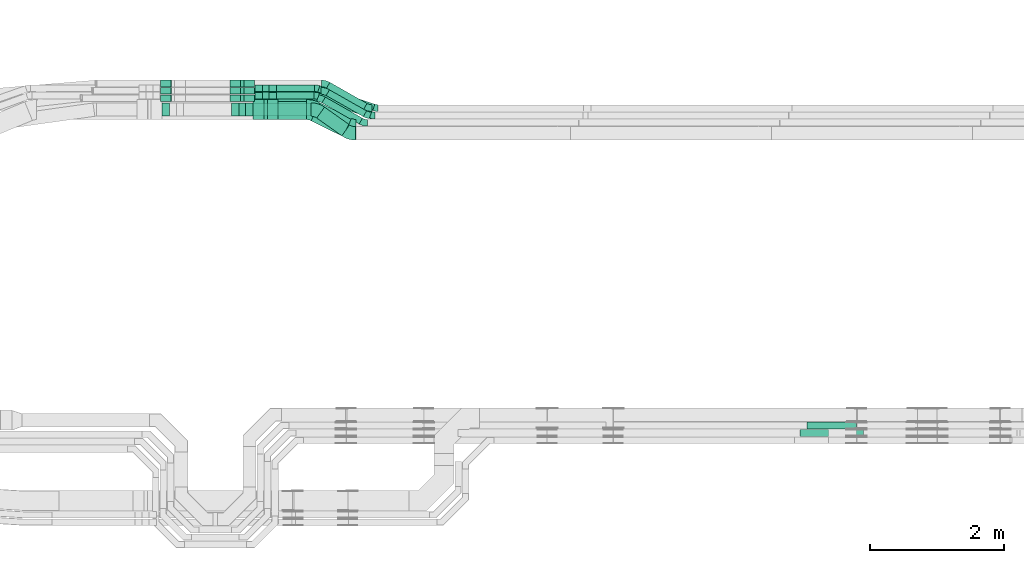
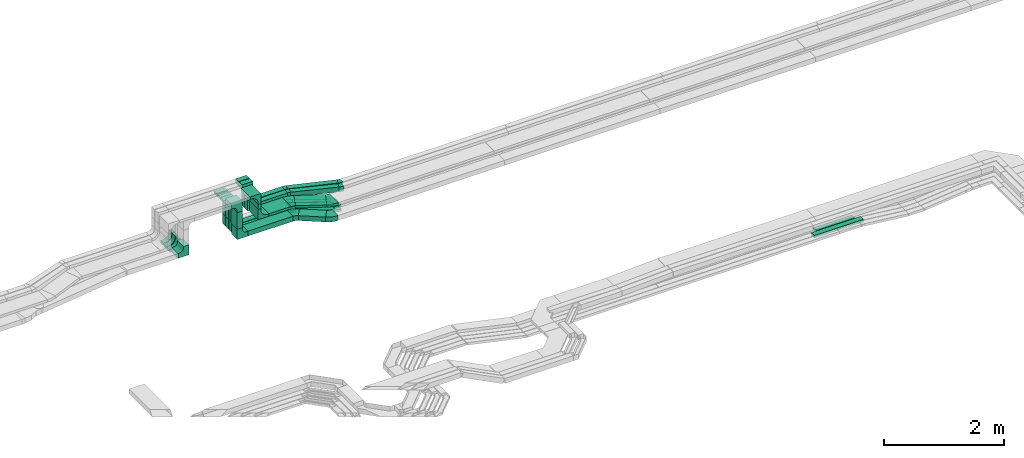
# One storey, part 17 of 32: 32 flow fittings, 22 flow segments.
"""IFC2X3 building model written with IfcOpenShell, lengths in millimetres."""

from ifc_helpers import new_model, entity, si_unit, converted_unit, derived_unit, direction, frame, frame_2d, origin, origin_2d_with_axis, place, context, subcontext, project, spatial, polyline, circle_curve, parameter, trimmed, segment, composite_curve, rectangle, outline, extrude, source, transform, mapped, material, type_object, type_shapes, element, save


model = new_model("IFC2X3")

# Units and contexts
model_context = context("Model", 3, precision=0.01, world=origin(), true_north=direction((6.12303176911189e-17, 1.0)))
body_context = subcontext(model_context, "Body", "Model", "MODEL_VIEW")
ifc_project = project(units=[si_unit("LENGTHUNIT", "METRE", prefix="MILLI"), si_unit("AREAUNIT", "SQUARE_METRE"), si_unit("VOLUMEUNIT", "CUBIC_METRE"), converted_unit("PLANEANGLEUNIT", "DEGREE", entity("IfcRatioMeasure", 0.0174532925199433), si_unit("PLANEANGLEUNIT", "RADIAN"), dimensions=[0, 0, 0, 0, 0, 0, 0]), si_unit("MASSUNIT", "GRAM", prefix="KILO"), derived_unit("MASSDENSITYUNIT", [(si_unit("MASSUNIT", "GRAM", prefix="KILO"), 1), (si_unit("LENGTHUNIT", "METRE"), -3)]), derived_unit("MOMENTOFINERTIAUNIT", [(si_unit("LENGTHUNIT", "METRE"), 4)]), si_unit("TIMEUNIT", "SECOND"), si_unit("FREQUENCYUNIT", "HERTZ"), si_unit("THERMODYNAMICTEMPERATUREUNIT", "DEGREE_CELSIUS"), derived_unit("THERMALTRANSMITTANCEUNIT", [(si_unit("MASSUNIT", "GRAM", prefix="KILO"), 1), (si_unit("THERMODYNAMICTEMPERATUREUNIT", "KELVIN"), -1), (si_unit("TIMEUNIT", "SECOND"), -3)]), derived_unit("VOLUMETRICFLOWRATEUNIT", [(si_unit("LENGTHUNIT", "METRE"), 3), (si_unit("TIMEUNIT", "SECOND"), -1)]), derived_unit("MASSFLOWRATEUNIT", [(si_unit("MASSUNIT", "GRAM", prefix="KILO"), 1), (si_unit("TIMEUNIT", "SECOND"), -1)]), derived_unit("ROTATIONALFREQUENCYUNIT", [(si_unit("TIMEUNIT", "SECOND"), -1)]), si_unit("ELECTRICCURRENTUNIT", "AMPERE"), si_unit("ELECTRICVOLTAGEUNIT", "VOLT"), si_unit("POWERUNIT", "WATT"), si_unit("FORCEUNIT", "NEWTON", prefix="KILO"), si_unit("ILLUMINANCEUNIT", "LUX"), si_unit("LUMINOUSFLUXUNIT", "LUMEN"), si_unit("LUMINOUSINTENSITYUNIT", "CANDELA"), derived_unit("USERDEFINED", [(si_unit("MASSUNIT", "GRAM", prefix="KILO"), -1), (si_unit("LENGTHUNIT", "METRE"), -2), (si_unit("TIMEUNIT", "SECOND"), 3), (si_unit("LUMINOUSFLUXUNIT", "LUMEN"), 1)]), derived_unit("LINEARVELOCITYUNIT", [(si_unit("LENGTHUNIT", "METRE"), 1), (si_unit("TIMEUNIT", "SECOND"), -1)]), si_unit("PRESSUREUNIT", "PASCAL"), derived_unit("USERDEFINED", [(si_unit("LENGTHUNIT", "METRE"), -2), (si_unit("MASSUNIT", "GRAM", prefix="KILO"), 1), (si_unit("TIMEUNIT", "SECOND"), -2)]), derived_unit("LINEARFORCEUNIT", [(si_unit("MASSUNIT", "GRAM", prefix="KILO"), 1), (si_unit("LENGTHUNIT", "METRE"), 1), (si_unit("TIMEUNIT", "SECOND"), -2), (si_unit("LENGTHUNIT", "METRE"), -1)]), derived_unit("PLANARFORCEUNIT", [(si_unit("MASSUNIT", "GRAM", prefix="KILO"), 1), (si_unit("LENGTHUNIT", "METRE"), 1), (si_unit("TIMEUNIT", "SECOND"), -2), (si_unit("LENGTHUNIT", "METRE"), -2)])], contexts=[model_context])

# Site, building, storey
site_placement = place(None, origin())
site = spatial("IfcSite", under=ifc_project, at=site_placement, CompositionType="ELEMENT")
building_placement = place(site_placement, origin())
building = spatial("IfcBuilding", under=site, at=building_placement, CompositionType="ELEMENT")
storey_placement = place(building_placement, frame((0.0, 0.0, 8100.0)))
storey = spatial("IfcBuildingStorey", under=building, at=storey_placement, CompositionType="ELEMENT", Elevation=8100.0)

# Flow segments
cable_carrier_segment_type = type_object("IfcCableCarrierSegmentType", PredefinedType="CABLETRAYSEGMENT")
flow_segment_1_placement = place(storey_placement, frame((30931.41, 14532.28, 2758.88)))
element("IfcFlowSegment", 1, at=flow_segment_1_placement, inside=storey, type_object=cable_carrier_segment_type, context=body_context, shape_type="SweptSolid", body=[
    extrude(rectangle(XDim=199.999999999998, YDim=100.000000000003, at=origin_2d_with_axis()), frame((50.0, 100.0, 0.0), z_axis=(0.0, 0.0, 1.0), x_axis=(0.0, -1.0, 0.0)), (0.0, 0.0, 1.0), 341.12169575336),
])
flow_segment_2_placement = place(storey_placement, frame((31166.41, 14750.06, 2548.88)))
element("IfcFlowSegment", 2, at=flow_segment_2_placement, inside=storey, type_object=cable_carrier_segment_type, context=body_context, shape_type="SweptSolid", body=[
    extrude(rectangle(XDim=930.329654405807, YDim=99.9999999999989, at=origin_2d_with_axis()), frame((465.16, 50.0, 0.0)), (0.0, 0.0, 1.0), 50.0000000000016),
])
flow_segment_3_placement = place(storey_placement, frame((30956.41, 14750.06, 2758.88)))
element("IfcFlowSegment", 3, at=flow_segment_3_placement, inside=storey, type_object=cable_carrier_segment_type, context=body_context, shape_type="SweptSolid", body=[
    extrude(rectangle(XDim=99.9999999999989, YDim=49.9999999999973, at=origin_2d_with_axis()), frame((25.0, 50.0, 0.0), z_axis=(0.0, 0.0, 1.0), x_axis=(0.0, -1.0, 0.0)), (0.0, 0.0, 1.0), 291.118753620383),
])
flow_segment_4_placement = place(storey_placement, frame((30956.41, 14860.06, 2758.35)))
element("IfcFlowSegment", 4, at=flow_segment_4_placement, inside=storey, type_object=cable_carrier_segment_type, context=body_context, shape_type="SweptSolid", body=[
    extrude(rectangle(XDim=99.9999999999989, YDim=49.9999999999973, at=origin_2d_with_axis()), frame((25.0, 50.0, 0.0), z_axis=(0.0, 0.0, 1.0), x_axis=(0.0, -1.0, 0.0)), (0.0, 0.0, 1.0), 291.650295473346),
])
flow_segment_5_placement = place(storey_placement, frame((39414.26, 9865.0, 2544.93)))
element("IfcFlowSegment", 5, at=flow_segment_5_placement, inside=storey, type_object=cable_carrier_segment_type, context=body_context, shape_type="SweptSolid", body=[
    extrude(rectangle(XDim=734.864056960746, YDim=99.9999999999989, at=origin_2d_with_axis()), frame((367.43, 50.0, 0.0)), (0.0, 0.0, 1.0), 50.0000000000016),
])
flow_segment_6_placement = place(storey_placement, frame((39304.26, 9755.0, 2546.32)))
element("IfcFlowSegment", 6, at=flow_segment_6_placement, inside=storey, type_object=cable_carrier_segment_type, context=body_context, shape_type="SweptSolid", body=[
    extrude(rectangle(XDim=948.992857325044, YDim=99.9999999999989, at=origin_2d_with_axis()), frame((474.5, 50.0, 0.0)), (0.0, 0.0, 1.0), 50.0000000000016),
])
flow_segment_7_placement = place(storey_placement, frame((30956.41, 14970.06, 2758.87)))
element("IfcFlowSegment", 7, at=flow_segment_7_placement, inside=storey, type_object=cable_carrier_segment_type, context=body_context, shape_type="SweptSolid", body=[
    extrude(rectangle(XDim=99.9999999999989, YDim=49.9999999999973, at=origin_2d_with_axis()), frame((25.0, 50.0, 0.0), z_axis=(0.0, 0.0, 1.0), x_axis=(0.0, -1.0, 0.0)), (0.0, 0.0, 1.0), 291.131430687611),
])
for number, where in (
    (8, (31281.41, 14900.06, 3065.0)),
    (9, (31281.41, 14790.06, 3065.0)),
):
    element("IfcFlowSegment", number, at=place(storey_placement, frame(where)), inside=storey, type_object=cable_carrier_segment_type, context=body_context, shape_type="SweptSolid", body=[
        extrude(rectangle(XDim=99.9999999999989, YDim=100.000000000003, at=origin_2d_with_axis()), frame((50.0, 50.0, 0.0), z_axis=(0.0, 0.0, 1.0), x_axis=(0.0, -1.0, 0.0)), (0.0, 0.0, 1.0), 149.998679724358),
    ])
flow_segment_8_placement = place(storey_placement, frame((31306.41, 14480.06, 3064.5)))
element("IfcFlowSegment", 10, at=flow_segment_8_placement, inside=storey, type_object=cable_carrier_segment_type, context=body_context, shape_type="SweptSolid", body=[
    extrude(rectangle(XDim=300.000000000001, YDim=49.9999999999973, at=origin_2d_with_axis()), frame((25.0, 150.0, 0.0), z_axis=(0.0, 0.0, 1.0), x_axis=(0.0, -1.0, 0.0)), (0.0, 0.0, 1.0), 100.501340766892),
])
flow_segment_9_placement = place(storey_placement, frame((31516.41, 14480.06, 2854.5)))
element("IfcFlowSegment", 11, at=flow_segment_9_placement, inside=storey, type_object=cable_carrier_segment_type, context=body_context, shape_type="SweptSolid", body=[
    extrude(rectangle(XDim=424.417391840432, YDim=300.000000000001, at=origin_2d_with_axis()), frame((212.21, 150.0, 0.0)), (0.0, 0.0, 1.0), 50.0000000000016),
])
flow_segment_10_placement = place(storey_placement, frame((31166.41, 14860.06, 2548.35)))
element("IfcFlowSegment", 12, at=flow_segment_10_placement, inside=storey, type_object=cable_carrier_segment_type, context=body_context, shape_type="SweptSolid", body=[
    extrude(rectangle(XDim=992.779967028208, YDim=99.9999999999989, at=origin_2d_with_axis()), frame((496.39, 50.0, 0.0), z_axis=(0.0, 0.0, 1.0), x_axis=(-1.0, 0.0, 0.0)), (0.0, 0.0, 1.0), 50.0000000000016),
])
flow_segment_11_placement = place(storey_placement, frame((31141.41, 14532.28, 2548.88)))
element("IfcFlowSegment", 13, at=flow_segment_11_placement, inside=storey, type_object=cable_carrier_segment_type, context=body_context, shape_type="SweptSolid", body=[
    extrude(rectangle(XDim=864.32109174626, YDim=199.999999999998, at=origin_2d_with_axis()), frame((432.16, 100.0, 0.0)), (0.0, 0.0, 1.0), 99.9999999999989),
])
flow_segment_12_placement = place(storey_placement, frame((32009.41, 14229.64, 2854.5)))
element("IfcFlowSegment", 14, at=flow_segment_12_placement, inside=storey, type_object=cable_carrier_segment_type, context=body_context, shape_type="SweptSolid", body=[
    extrude(rectangle(XDim=527.080933740967, YDim=299.999999999999, at=origin_2d_with_axis()), frame((302.75, 251.53, 0.0), z_axis=(0.0, 0.0, 1.0), x_axis=(-0.895736929927625, 0.444584471572987, 0.0)), (0.0, 0.0, 1.0), 50.0000000000016),
])
flow_segment_13_placement = place(storey_placement, frame((32094.18, 14239.35, 2548.88)))
element("IfcFlowSegment", 15, at=flow_segment_13_placement, inside=storey, type_object=cable_carrier_segment_type, context=body_context, shape_type="SweptSolid", body=[
    extrude(rectangle(XDim=458.510292454723, YDim=200.000000000002, at=origin_2d_with_axis()), frame((244.91, 214.04, 0.0), z_axis=(0.0, 0.0, 1.0), x_axis=(-0.816364917109081, 0.577536424923557, 0.0)), (0.0, 0.0, 1.0), 99.9999999999989),
])
flow_segment_14_placement = place(storey_placement, frame((32235.12, 14525.37, 2548.35)))
element("IfcFlowSegment", 16, at=flow_segment_14_placement, inside=storey, type_object=cable_carrier_segment_type, context=body_context, shape_type="SweptSolid", body=[
    extrude(rectangle(XDim=637.297455532549, YDim=100.000000000004, at=origin_2d_with_axis()), frame((301.79, 200.8, 0.0), z_axis=(0.0, 0.0, 1.0), x_axis=(-0.869625227484752, 0.493712430187952, 0.0)), (0.0, 0.0, 1.0), 50.0000000000016),
])
flow_segment_15_placement = place(storey_placement, frame((32172.67, 14415.37, 2548.88)))
element("IfcFlowSegment", 17, at=flow_segment_15_placement, inside=storey, type_object=cable_carrier_segment_type, context=body_context, shape_type="SweptSolid", body=[
    extrude(rectangle(XDim=637.297455532608, YDim=99.9999999999995, at=origin_2d_with_axis()), frame((301.79, 200.8, 0.0), z_axis=(0.0, 0.0, 1.0), x_axis=(-0.869625227484766, 0.493712430187927, 0.0)), (0.0, 0.0, 1.0), 50.0000000000016),
])
flow_segment_16_placement = place(storey_placement, frame((32240.6, 14635.37, 2548.87)))
element("IfcFlowSegment", 18, at=flow_segment_16_placement, inside=storey, type_object=cable_carrier_segment_type, context=body_context, shape_type="SweptSolid", body=[
    extrude(rectangle(XDim=637.297455532466, YDim=100.0, at=origin_2d_with_axis()), frame((301.79, 200.8, 0.0), z_axis=(0.0, 0.0, 1.0), x_axis=(-0.869625227484736, 0.49371243018798, 0.0)), (0.0, 0.0, 1.0), 50.0000000000016),
])
flow_segment_17_placement = place(storey_placement, frame((32109.51, 14615.66, 2855.0)))
element("IfcFlowSegment", 19, at=flow_segment_17_placement, inside=storey, type_object=cable_carrier_segment_type, context=body_context, shape_type="SweptSolid", body=[
    extrude(rectangle(XDim=865.944698440222, YDim=100.000000000001, at=origin_2d_with_axis()), frame((426.3, 185.51, 0.0), z_axis=(0.0, 0.0, 1.0), x_axis=(0.947752520609184, -0.319006519806318, 0.0)), (0.0, 0.0, 1.0), 99.9999999999989),
])
flow_segment_18_placement = place(storey_placement, frame((31491.41, 14900.06, 2855.0)))
element("IfcFlowSegment", 20, at=flow_segment_18_placement, inside=storey, type_object=cable_carrier_segment_type, context=body_context, shape_type="SweptSolid", body=[
    extrude(rectangle(XDim=568.300597632481, YDim=99.9999999999989, at=origin_2d_with_axis()), frame((284.15, 50.0, 0.0)), (0.0, 0.0, 1.0), 99.9999999999989),
])
flow_segment_19_placement = place(storey_placement, frame((32102.16, 14506.81, 2855.0)))
element("IfcFlowSegment", 21, at=flow_segment_19_placement, inside=storey, type_object=cable_carrier_segment_type, context=body_context, shape_type="SweptSolid", body=[
    extrude(rectangle(XDim=826.032338291808, YDim=99.9999999999999, at=origin_2d_with_axis()), frame((406.17, 184.36, 0.0), z_axis=(0.0, 0.0, 1.0), x_axis=(0.943212511924906, -0.332189941672396, 0.0)), (0.0, 0.0, 1.0), 99.9999999999989),
])
flow_segment_20_placement = place(storey_placement, frame((31491.41, 14790.06, 2855.0)))
element("IfcFlowSegment", 22, at=flow_segment_20_placement, inside=storey, type_object=cable_carrier_segment_type, context=body_context, shape_type="SweptSolid", body=[
    extrude(rectangle(XDim=558.972805625544, YDim=99.9999999999989, at=origin_2d_with_axis()), frame((279.49, 50.0, 0.0)), (0.0, 0.0, 1.0), 99.9999999999989),
])

# Flow fittings
ifc_material = material()
cable_carrier_fitting_type_1 = type_object("IfcCableCarrierFittingType", Name="470_DKC_S5_CDV 90 external vertical angle:-", PredefinedType="NOTDEFINED", material=ifc_material)
shared_shape_1 = source(origin(), body_context, "Body", "SweptSolid", [
    extrude(outline(composite_curve([segment(polyline([(65.71, 14.29), (95.71, 14.29)]), True, "CONTINUOUS"), segment(polyline([(95.71, 14.29), (95.71, 114.29)]), True, "CONTINUOUS"), segment(polyline([(95.71, 114.29), (-114.29, 114.29)]), True, "CONTINUOUS"), segment(polyline([(-114.29, 114.29), (-114.29, -95.71)]), True, "CONTINUOUS"), segment(polyline([(-114.29, -95.71), (-14.29, -95.71)]), True, "CONTINUOUS"), segment(polyline([(-14.29, -95.71), (-14.29, -65.71)]), True, "CONTINUOUS"), segment(trimmed(circle_curve(frame_2d((65.71, -65.71), x_axis=(-1.0, 0.0)), 80.0), [parameter(270.0)], [parameter(2.54444374517082e-13)], True, "PARAMETER"), False, "CONTINUOUS")], self_intersect=False)), frame((-64.29, 64.29, -99.0), z_axis=(0.0, 0.0, 1.0), x_axis=(-1.0, 0.0, 0.0)), (0.0, 0.0, 1.0), 199.0),
])
type_shapes(cable_carrier_fitting_type_1, [shared_shape_1])
for number, where, z_axis, x_axis, name in (
    (23, (30981.41, 14632.28, 3260.0), (0.0, -1.0, 0.0), (0.0, 0.0, 1.0), "470_DKC_S5_90 external vertical angle"),
    (24, (30981.41, 14632.28, 2598.88), (0.0, -1.0, 0.0), (0.0, 0.0, -1.0), "470_DKC_S5_90 external vertical angle"),
    (25, (29948.2, 14632.28, 2615.0), (0.0, 1.0, 0.0), (0.0, 0.0, -1.0), "470_DKC_S5_90 external vertical angle"),
):
    element("IfcFlowFitting", number, at=place(storey_placement, frame(where, z_axis=z_axis, x_axis=x_axis)), inside=storey, type_object=cable_carrier_fitting_type_1, material=ifc_material, Name=name, ObjectType="470_DKC_S5_CDV 90 external vertical angle:-", context=body_context, shape_type="MappedRepresentation", body=[
        mapped(shared_shape_1, transform((0.0, 0.0, 0.0), scale=1.0)),
    ])
cable_carrier_fitting_type_2 = type_object("IfcCableCarrierFittingType", Name="470_DKC_S5_CDV 90 external vertical angle:-", PredefinedType="NOTDEFINED", material=ifc_material)
shared_shape_2 = source(origin(), body_context, "Body", "SweptSolid", [
    extrude(outline(composite_curve([segment(polyline([(80.0, 50.0), (110.0, 50.0)]), True, "CONTINUOUS"), segment(polyline([(110.0, 50.0), (110.0, 100.0)]), True, "CONTINUOUS"), segment(polyline([(110.0, 100.0), (-100.0, 100.0)]), True, "CONTINUOUS"), segment(polyline([(-100.0, 100.0), (-100.0, -110.0)]), True, "CONTINUOUS"), segment(polyline([(-100.0, -110.0), (-50.0, -110.0)]), True, "CONTINUOUS"), segment(polyline([(-50.0, -110.0), (-50.0, -80.0)]), True, "CONTINUOUS"), segment(trimmed(circle_curve(frame_2d((80.0, -80.0), x_axis=(-1.0, 0.0)), 130.0), [parameter(270.0)], [parameter(2.54444374517082e-13)], True, "PARAMETER"), False, "CONTINUOUS")], self_intersect=False)), frame((-75.0, 75.0, -49.0), z_axis=(0.0, 0.0, 1.0), x_axis=(-1.0, 0.0, 0.0)), (0.0, 0.0, 1.0), 99.0000000000002),
])
type_shapes(cable_carrier_fitting_type_2, [shared_shape_2])
for number, where, z_axis, x_axis, name in (
    (26, (30981.41, 14800.06, 3235.0), (0.0, -1.0, 0.0), (0.0, 0.0, 1.0), "470_DKC_S5_90 external vertical angle"),
    (27, (30981.41, 14910.06, 3235.0), (0.0, -1.0, 0.0), (0.0, 0.0, 1.0), "470_DKC_S5_90 external vertical angle"),
    (28, (30981.41, 15020.06, 3235.0), (0.0, -1.0, 0.0), (0.0, 0.0, 1.0), "470_DKC_S5_90 external vertical angle"),
    (29, (30981.41, 14910.06, 2573.35), (0.0, -1.0, 0.0), (0.0, 0.0, -1.0), "470_DKC_S5_90 external vertical angle"),
    (30, (30981.41, 14800.06, 2573.88), (0.0, -1.0, 0.0), (0.0, 0.0, -1.0), "470_DKC_S5_90 external vertical angle"),
    (31, (30981.41, 15020.06, 2573.87), (0.0, -1.0, 0.0), (0.0, 0.0, -1.0), "470_DKC_S5_90 external vertical angle"),
    (32, (29948.2, 14800.06, 2590.34), (0.0, 1.0, 0.0), (0.0, 0.0, -1.0), "470_DKC_S5_90 external vertical angle"),
    (33, (29948.2, 15020.06, 2595.0), (0.0, 1.0, 0.0), (0.0, 0.0, -1.0), "470_DKC_S5_90 external vertical angle"),
    (34, (29948.2, 14910.06, 2595.0), (0.0, 1.0, 0.0), (0.0, 0.0, -1.0), "470_DKC_S5_90 external vertical angle"),
):
    element("IfcFlowFitting", number, at=place(storey_placement, frame(where, z_axis=z_axis, x_axis=x_axis)), inside=storey, type_object=cable_carrier_fitting_type_2, material=ifc_material, Name=name, ObjectType="470_DKC_S5_CDV 90 external vertical angle:-", context=body_context, shape_type="MappedRepresentation", body=[
        mapped(shared_shape_2, transform((0.0, 0.0, 0.0), scale=1.0)),
    ])
cable_carrier_fitting_type_3 = type_object("IfcCableCarrierFittingType", Name="470_DKC_S5_CDV 90 external vertical angle:-", PredefinedType="NOTDEFINED", material=ifc_material)
shared_shape_3 = source(origin(), body_context, "Body", "SweptSolid", [
    extrude(outline(composite_curve([segment(polyline([(65.71, 14.29), (95.71, 14.29)]), True, "CONTINUOUS"), segment(polyline([(95.71, 14.29), (95.71, 114.29)]), True, "CONTINUOUS"), segment(polyline([(95.71, 114.29), (-114.29, 114.29)]), True, "CONTINUOUS"), segment(polyline([(-114.29, 114.29), (-114.29, -95.71)]), True, "CONTINUOUS"), segment(polyline([(-114.29, -95.71), (-14.29, -95.71)]), True, "CONTINUOUS"), segment(polyline([(-14.29, -95.71), (-14.29, -65.71)]), True, "CONTINUOUS"), segment(trimmed(circle_curve(frame_2d((65.71, -65.71), x_axis=(-1.0, 0.0)), 80.0), [parameter(270.0)], [parameter(2.54444374517082e-13)], True, "PARAMETER"), False, "CONTINUOUS")], self_intersect=False)), frame((-64.29, 64.29, -49.0), z_axis=(0.0, 0.0, 1.0), x_axis=(-1.0, 0.0, 0.0)), (0.0, 0.0, 1.0), 99.0000000000002),
])
type_shapes(cable_carrier_fitting_type_3, [shared_shape_3])
for number, where, z_axis, x_axis, name in (
    (35, (31331.41, 14950.06, 3375.0), (0.0, -1.0, 0.0), (0.0, 0.0, 1.0), "470_DKC_S5_90 external vertical angle"),
    (36, (31331.41, 14840.06, 3375.0), (0.0, -1.0, 0.0), (0.0, 0.0, 1.0), "470_DKC_S5_90 external vertical angle"),
    (37, (31331.41, 14950.06, 2905.0), (0.0, -1.0, 0.0), (0.0, 0.0, -1.0), "470_DKC_S5_90 external vertical angle"),
    (38, (31331.41, 14840.06, 2905.0), (0.0, -1.0, 0.0), (0.0, 0.0, -1.0), "470_DKC_S5_90 external vertical angle"),
):
    element("IfcFlowFitting", number, at=place(storey_placement, frame(where, z_axis=z_axis, x_axis=x_axis)), inside=storey, type_object=cable_carrier_fitting_type_3, material=ifc_material, Name=name, ObjectType="470_DKC_S5_CDV 90 external vertical angle:-", context=body_context, shape_type="MappedRepresentation", body=[
        mapped(shared_shape_3, transform((0.0, 0.0, 0.0), scale=1.0)),
    ])
cable_carrier_fitting_type_4 = type_object("IfcCableCarrierFittingType", Name="470_DKC_S5_CDV 90 external vertical angle:-", PredefinedType="NOTDEFINED", material=ifc_material)
shared_shape_4 = source(origin(), body_context, "Body", "SweptSolid", [
    extrude(outline(composite_curve([segment(polyline([(80.0, 50.0), (110.0, 50.0)]), True, "CONTINUOUS"), segment(polyline([(110.0, 50.0), (110.0, 100.0)]), True, "CONTINUOUS"), segment(polyline([(110.0, 100.0), (-100.0, 100.0)]), True, "CONTINUOUS"), segment(polyline([(-100.0, 100.0), (-100.0, -110.0)]), True, "CONTINUOUS"), segment(polyline([(-100.0, -110.0), (-50.0, -110.0)]), True, "CONTINUOUS"), segment(polyline([(-50.0, -110.0), (-50.0, -80.0)]), True, "CONTINUOUS"), segment(trimmed(circle_curve(frame_2d((80.0, -80.0), x_axis=(-1.0, 0.0)), 130.0), [parameter(270.0)], [parameter(2.54444374517082e-13)], True, "PARAMETER"), False, "CONTINUOUS")], self_intersect=False)), frame((-75.0, 75.0, -149.0), z_axis=(0.0, 0.0, 1.0), x_axis=(-1.0, 0.0, 0.0)), (0.0, 0.0, 1.0), 299.0),
])
type_shapes(cable_carrier_fitting_type_4, [shared_shape_4])
for number, where, z_axis, x_axis, name in (
    (39, (31331.41, 14630.06, 3350.0), (0.0, -1.0, 0.0), (0.0, 0.0, 1.0), "470_DKC_S5_90 external vertical angle"),
    (40, (31331.41, 14630.06, 2879.5), (0.0, -1.0, 0.0), (0.0, 0.0, -1.0), "470_DKC_S5_90 external vertical angle"),
):
    element("IfcFlowFitting", number, at=place(storey_placement, frame(where, z_axis=z_axis, x_axis=x_axis)), inside=storey, type_object=cable_carrier_fitting_type_4, material=ifc_material, Name=name, ObjectType="470_DKC_S5_CDV 90 external vertical angle:-", context=body_context, shape_type="MappedRepresentation", body=[
        mapped(shared_shape_4, transform((0.0, 0.0, 0.0), scale=1.0)),
    ])
cable_carrier_fitting_type_5 = type_object("IfcCableCarrierFittingType", Name="470_DKC_S5_Variable Angle Elbow 0-45:-", PredefinedType="NOTDEFINED", material=ifc_material)
shared_shape_5 = source(origin(), body_context, "Body", "SweptSolid", [
    extrude(outline(composite_curve([segment(polyline([(-67.66, -165.75), (-66.66, -165.75)]), True, "CONTINUOUS"), segment(trimmed(circle_curve(frame_2d((-66.66, 284.25), x_axis=(0.0, -1.0)), 450.0), [parameter(0.0)], [parameter(26.3967564439115)], True, "PARAMETER"), True, "CONTINUOUS"), segment(polyline([(133.4, -118.83), (134.3, -118.39)]), True, "CONTINUOUS"), segment(polyline([(134.3, -118.39), (0.92, 150.33)]), True, "CONTINUOUS"), segment(polyline([(0.92, 150.33), (0.03, 149.89)]), True, "CONTINUOUS"), segment(trimmed(circle_curve(frame_2d((-66.66, 284.25), x_axis=(0.0, -1.0)), 150.0), [parameter(0.0)], [parameter(26.3967564439115)], True, "PARAMETER"), False, "CONTINUOUS"), segment(polyline([(-66.66, 134.25), (-67.66, 134.25)]), True, "CONTINUOUS"), segment(polyline([(-67.66, 134.25), (-67.66, -165.75)]), True, "CONTINUOUS")], self_intersect=False)), frame((-3.69, 15.75, -25.0)), (0.0, 0.0, 1.0), 49.999999999999),
])
type_shapes(cable_carrier_fitting_type_5, [shared_shape_5])
for number, where, z_axis, x_axis, name in (
    (41, (32012.19, 14630.06, 2879.5), (0.0, 0.0, 1.0), (-0.895736929927626, 0.444584471572987, 0.0), "470_DKC_S5_Variable Angle Elbow 0-45:-"),
    (42, (32612.14, 14332.28, 2879.5), (0.0, 0.0, 1.0), (0.895736929927626, -0.444584471572987, 0.0), "470_DKC_S5_Variable Angle Elbow 0-45:-"),
):
    element("IfcFlowFitting", number, at=place(storey_placement, frame(where, z_axis=z_axis, x_axis=x_axis)), inside=storey, type_object=cable_carrier_fitting_type_5, material=ifc_material, Name=name, ObjectType="470_DKC_S5_Variable Angle Elbow 0-45:-", context=body_context, shape_type="MappedRepresentation", body=[
        mapped(shared_shape_5, transform((0.0, 0.0, 0.0), scale=1.0)),
    ])
cable_carrier_fitting_type_6 = type_object("IfcCableCarrierFittingType", Name="470_DKC_S5_Variable Angle Elbow 0-45:-", PredefinedType="NOTDEFINED", material=ifc_material)
shared_shape_6 = source(origin(), body_context, "Body", "SweptSolid", [
    extrude(outline(composite_curve([segment(polyline([(-73.15, -123.1), (-72.15, -123.1)]), True, "CONTINUOUS"), segment(trimmed(circle_curve(frame_2d((-72.15, 226.9), x_axis=(0.0, -1.0)), 350.0), [parameter(0.0)], [parameter(35.2774537887441)], True, "PARAMETER"), True, "CONTINUOUS"), segment(polyline([(129.99, -58.83), (130.81, -58.25)]), True, "CONTINUOUS"), segment(polyline([(130.81, -58.25), (15.3, 105.02)]), True, "CONTINUOUS"), segment(polyline([(15.3, 105.02), (14.48, 104.45)]), True, "CONTINUOUS"), segment(trimmed(circle_curve(frame_2d((-72.15, 226.9), x_axis=(0.0, -1.0)), 150.0), [parameter(0.0)], [parameter(35.2774537887441)], True, "PARAMETER"), False, "CONTINUOUS"), segment(polyline([(-72.15, 76.9), (-73.15, 76.9)]), True, "CONTINUOUS"), segment(polyline([(-73.15, 76.9), (-73.15, -123.1)]), True, "CONTINUOUS")], self_intersect=False)), frame((-7.34, 23.1, -50.0)), (0.0, 0.0, 1.0), 100.0),
])
type_shapes(cable_carrier_fitting_type_6, [shared_shape_6])
for number, where, z_axis, x_axis, name in (
    (43, (32591.96, 14274.5, 2598.88), (0.0, 0.0, 1.0), (0.816364917109106, -0.577536424923522, 0.0), "470_DKC_S5_Variable Angle Elbow 0-45:-"),
    (44, (32086.22, 14632.28, 2598.88), (0.0, 0.0, 1.0), (-0.81636491710906, 0.577536424923586, 0.0), "470_DKC_S5_Variable Angle Elbow 0-45:-"),
):
    element("IfcFlowFitting", number, at=place(storey_placement, frame(where, z_axis=z_axis, x_axis=x_axis)), inside=storey, type_object=cable_carrier_fitting_type_6, material=ifc_material, Name=name, ObjectType="470_DKC_S5_Variable Angle Elbow 0-45:-", context=body_context, shape_type="MappedRepresentation", body=[
        mapped(shared_shape_6, transform((0.0, 0.0, 0.0), scale=1.0)),
    ])
cable_carrier_fitting_type_7 = type_object("IfcCableCarrierFittingType", Name="470_DKC_S5_Variable Angle Elbow 0-45:-", PredefinedType="NOTDEFINED", material=ifc_material)
shared_shape_7 = source(origin(), body_context, "Body", "SweptSolid", [
    extrude(outline(composite_curve([segment(polyline([(-50.34, -63.16), (-49.34, -63.16)]), True, "CONTINUOUS"), segment(trimmed(circle_curve(frame_2d((-49.34, 186.84), x_axis=(0.0, -1.0)), 250.0), [parameter(0.0)], [parameter(29.5848823129969)], True, "PARAMETER"), True, "CONTINUOUS"), segment(polyline([(74.09, -30.57), (74.96, -30.07)]), True, "CONTINUOUS"), segment(polyline([(74.96, -30.07), (25.59, 56.89)]), True, "CONTINUOUS"), segment(polyline([(25.59, 56.89), (24.72, 56.4)]), True, "CONTINUOUS"), segment(trimmed(circle_curve(frame_2d((-49.34, 186.84), x_axis=(0.0, -1.0)), 150.0), [parameter(0.0)], [parameter(29.5848823129969)], True, "PARAMETER"), False, "CONTINUOUS"), segment(polyline([(-49.34, 36.84), (-50.34, 36.84)]), True, "CONTINUOUS"), segment(polyline([(-50.34, 36.84), (-50.34, -63.16)]), True, "CONTINUOUS")], self_intersect=False)), frame((-3.48, 13.16, -25.0)), (0.0, 0.0, 1.0), 50.0),
])
type_shapes(cable_carrier_fitting_type_7, [shared_shape_7])
for number, where, z_axis, x_axis, name in (
    (45, (32213.01, 14910.06, 2573.35), (0.0, 0.0, 1.0), (-0.869625227484751, 0.493712430187954, 0.0), "470_DKC_S5_Variable Angle Elbow 0-45:-"),
    (46, (32150.56, 14800.06, 2573.88), (0.0, 0.0, 1.0), (-0.869625227484763, 0.493712430187932, 0.0), "470_DKC_S5_Variable Angle Elbow 0-45:-"),
    (47, (32798.36, 14432.28, 2573.88), (0.0, 0.0, 1.0), (0.869625227484763, -0.493712430187932, 0.0), "470_DKC_S5_Variable Angle Elbow 0-45:-"),
    (48, (32866.29, 14652.28, 2573.87), (0.0, 0.0, 1.0), (0.869625227484745, -0.493712430187964, 0.0), "470_DKC_S5_Variable Angle Elbow 0-45:-"),
    (49, (32218.48, 15020.06, 2573.87), (0.0, 0.0, 1.0), (-0.869625227484732, 0.493712430187987, 0.0), "470_DKC_S5_Variable Angle Elbow 0-45:-"),
    (50, (32860.81, 14542.28, 2573.35), (0.0, 0.0, 1.0), (0.869625227484747, -0.49371243018796, 0.0), "470_DKC_S5_Variable Angle Elbow 0-45:-"),
):
    element("IfcFlowFitting", number, at=place(storey_placement, frame(where, z_axis=z_axis, x_axis=x_axis)), inside=storey, type_object=cable_carrier_fitting_type_7, material=ifc_material, Name=name, ObjectType="470_DKC_S5_Variable Angle Elbow 0-45:-", context=body_context, shape_type="MappedRepresentation", body=[
        mapped(shared_shape_7, transform((0.0, 0.0, 0.0), scale=1.0)),
    ])
cable_carrier_fitting_type_8 = type_object("IfcCableCarrierFittingType", Name="470_DKC_S5_Variable Angle Elbow 0-45:-", PredefinedType="NOTDEFINED", material=ifc_material)
shared_shape_8 = source(origin(), body_context, "Body", "SweptSolid", [
    extrude(outline(composite_curve([segment(polyline([(-32.89, -55.3), (-31.89, -55.3)]), True, "CONTINUOUS"), segment(trimmed(circle_curve(frame_2d((-31.89, 194.7), x_axis=(0.0, -1.0)), 250.0), [parameter(0.0)], [parameter(18.6028540575066)], True, "PARAMETER"), True, "CONTINUOUS"), segment(polyline([(47.86, -42.24), (48.81, -41.92)]), True, "CONTINUOUS"), segment(polyline([(48.81, -41.92), (16.91, 52.85)]), True, "CONTINUOUS"), segment(polyline([(16.91, 52.85), (15.96, 52.53)]), True, "CONTINUOUS"), segment(trimmed(circle_curve(frame_2d((-31.89, 194.7), x_axis=(0.0, -1.0)), 150.0), [parameter(0.0)], [parameter(18.6028540575066)], True, "PARAMETER"), False, "CONTINUOUS"), segment(polyline([(-31.89, 44.7), (-32.89, 44.7)]), True, "CONTINUOUS"), segment(polyline([(-32.89, 44.7), (-32.89, -55.3)]), True, "CONTINUOUS")], self_intersect=False)), frame((-0.87, 5.3, -50.0)), (0.0, 0.0, 1.0), 100.0),
])
type_shapes(cable_carrier_fitting_type_8, [shared_shape_8])
for number, where, z_axis, x_axis, name in (
    (51, (32093.47, 14950.06, 2905.0), (0.0, 0.0, 1.0), (-0.947752520609185, 0.319006519806315, 0.0), "470_DKC_S5_Variable Angle Elbow 0-45:-"),
    (52, (32978.16, 14652.28, 2905.0), (0.0, 0.0, 1.0), (0.947752520609181, -0.319006519806326, 0.0), "470_DKC_S5_Variable Angle Elbow 0-45:-"),
):
    element("IfcFlowFitting", number, at=place(storey_placement, frame(where, z_axis=z_axis, x_axis=x_axis)), inside=storey, type_object=cable_carrier_fitting_type_8, material=ifc_material, Name=name, ObjectType="470_DKC_S5_Variable Angle Elbow 0-45:-", context=body_context, shape_type="MappedRepresentation", body=[
        mapped(shared_shape_8, transform((0.0, 0.0, 0.0), scale=1.0)),
    ])
cable_carrier_fitting_type_9 = type_object("IfcCableCarrierFittingType", Name="470_DKC_S5_Variable Angle Elbow 0-45:-", PredefinedType="NOTDEFINED", material=ifc_material)
shared_shape_9 = source(origin(), body_context, "Body", "SweptSolid", [
    extrude(outline(composite_curve([segment(polyline([(-34.2, -55.76), (-33.2, -55.76)]), True, "CONTINUOUS"), segment(trimmed(circle_curve(frame_2d((-33.2, 194.24), x_axis=(0.0, -1.0)), 250.0), [parameter(0.0)], [parameter(19.4017500514484)], True, "PARAMETER"), True, "CONTINUOUS"), segment(polyline([(49.84, -41.56), (50.79, -41.23)]), True, "CONTINUOUS"), segment(polyline([(50.79, -41.23), (17.57, 53.09)]), True, "CONTINUOUS"), segment(polyline([(17.57, 53.09), (16.62, 52.76)]), True, "CONTINUOUS"), segment(trimmed(circle_curve(frame_2d((-33.2, 194.24), x_axis=(0.0, -1.0)), 150.0), [parameter(0.0)], [parameter(19.4017500514484)], True, "PARAMETER"), False, "CONTINUOUS"), segment(polyline([(-33.2, 44.24), (-34.2, 44.24)]), True, "CONTINUOUS"), segment(polyline([(-34.2, 44.24), (-34.2, -55.76)]), True, "CONTINUOUS")], self_intersect=False)), frame((-0.98, 5.76, -50.0)), (0.0, 0.0, 1.0), 100.0),
])
type_shapes(cable_carrier_fitting_type_9, [shared_shape_9])
for number, where, z_axis, x_axis, name in (
    (53, (32085.58, 14840.06, 2905.0), (0.0, 0.0, 1.0), (-0.943212511924905, 0.332189941672396, 0.0), "470_DKC_S5_Variable Angle Elbow 0-45:-"),
    (54, (32931.08, 14542.28, 2905.0), (0.0, 0.0, 1.0), (0.943212511924902, -0.332189941672405, 0.0), "470_DKC_S5_Variable Angle Elbow 0-45:-"),
):
    element("IfcFlowFitting", number, at=place(storey_placement, frame(where, z_axis=z_axis, x_axis=x_axis)), inside=storey, type_object=cable_carrier_fitting_type_9, material=ifc_material, Name=name, ObjectType="470_DKC_S5_Variable Angle Elbow 0-45:-", context=body_context, shape_type="MappedRepresentation", body=[
        mapped(shared_shape_9, transform((0.0, 0.0, 0.0), scale=1.0)),
    ])

save(model, "model.ifc")
